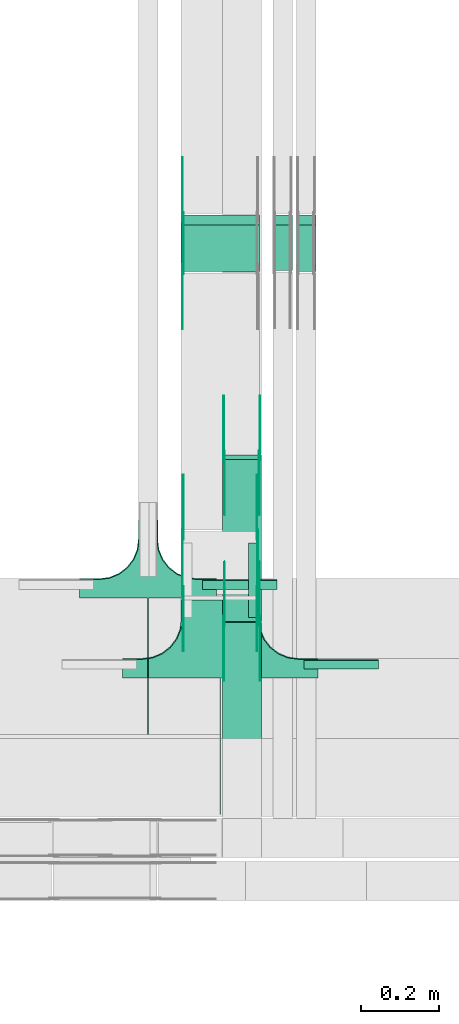
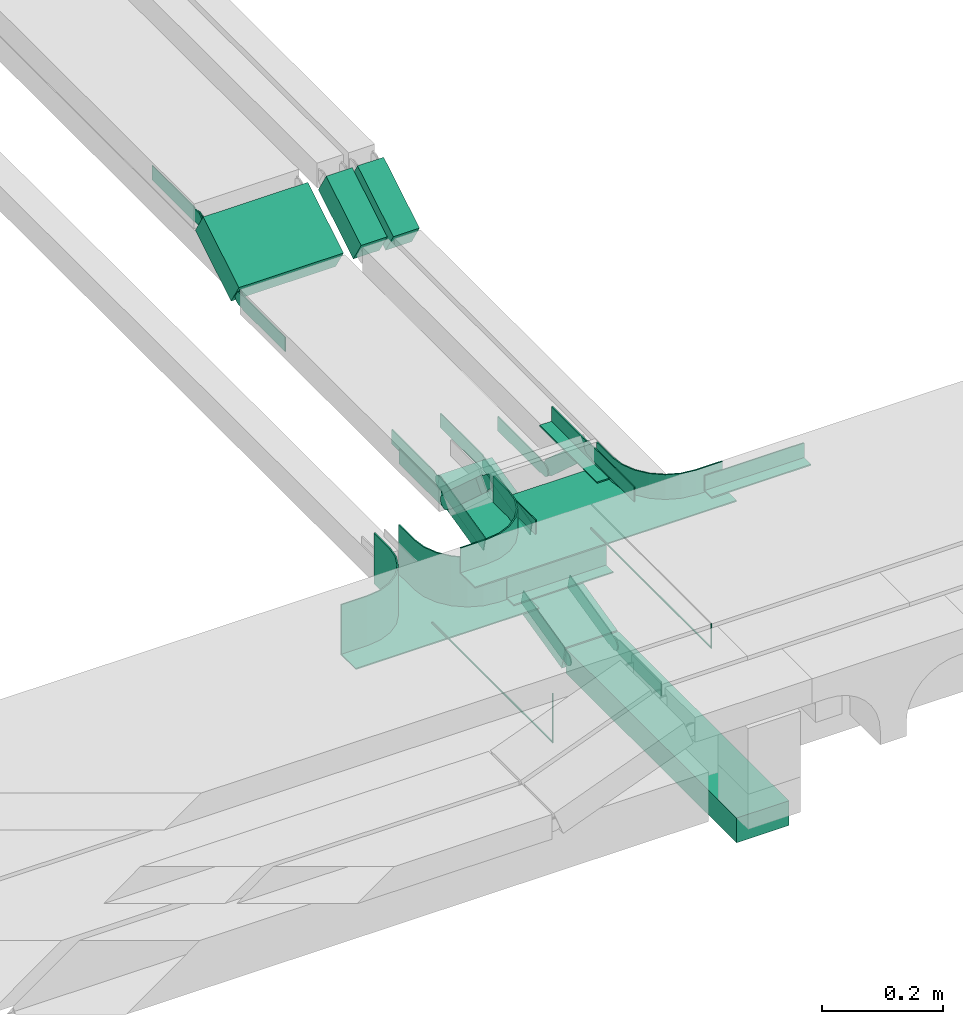
# One storey, part 24 of 27: 25 flow fittings, 5 flow segments.
"""IFC2X3 building model written with IfcOpenShell, lengths in millimetres."""

from ifc_helpers import new_model, entity, si_unit, converted_unit, derived_unit, direction, frame, frame_2d, origin, origin_2d_with_axis, place, context, subcontext, project, spatial, polyline, circle_curve, parameter, trimmed, segment, composite_curve, rectangle, outline, extrude, faceted_brep, source, transform, mapped, material, type_object, type_shapes, element, save


model = new_model("IFC2X3")

# Units and contexts
model_context = context("Model", 3, precision=0.01, world=origin(), true_north=direction((6.12303176911189e-17, 1.0)))
body_context = subcontext(model_context, "Body", "Model", "MODEL_VIEW")
ifc_project = project(units=[si_unit("LENGTHUNIT", "METRE", prefix="MILLI"), si_unit("AREAUNIT", "SQUARE_METRE"), si_unit("VOLUMEUNIT", "CUBIC_METRE"), converted_unit("PLANEANGLEUNIT", "DEGREE", entity("IfcRatioMeasure", 0.0174532925199433), si_unit("PLANEANGLEUNIT", "RADIAN"), dimensions=[0, 0, 0, 0, 0, 0, 0]), si_unit("MASSUNIT", "GRAM", prefix="KILO"), derived_unit("MASSDENSITYUNIT", [(si_unit("MASSUNIT", "GRAM", prefix="KILO"), 1), (si_unit("LENGTHUNIT", "METRE"), -3)]), derived_unit("MOMENTOFINERTIAUNIT", [(si_unit("LENGTHUNIT", "METRE"), 4)]), si_unit("TIMEUNIT", "SECOND"), si_unit("FREQUENCYUNIT", "HERTZ"), si_unit("THERMODYNAMICTEMPERATUREUNIT", "DEGREE_CELSIUS"), derived_unit("THERMALTRANSMITTANCEUNIT", [(si_unit("MASSUNIT", "GRAM", prefix="KILO"), 1), (si_unit("THERMODYNAMICTEMPERATUREUNIT", "KELVIN"), -1), (si_unit("TIMEUNIT", "SECOND"), -3)]), derived_unit("VOLUMETRICFLOWRATEUNIT", [(si_unit("LENGTHUNIT", "METRE"), 3), (si_unit("TIMEUNIT", "SECOND"), -1)]), derived_unit("MASSFLOWRATEUNIT", [(si_unit("MASSUNIT", "GRAM", prefix="KILO"), 1), (si_unit("TIMEUNIT", "SECOND"), -1)]), derived_unit("ROTATIONALFREQUENCYUNIT", [(si_unit("TIMEUNIT", "SECOND"), -1)]), si_unit("ELECTRICCURRENTUNIT", "AMPERE"), si_unit("ELECTRICVOLTAGEUNIT", "VOLT"), si_unit("POWERUNIT", "WATT"), si_unit("FORCEUNIT", "NEWTON", prefix="KILO"), si_unit("ILLUMINANCEUNIT", "LUX"), si_unit("LUMINOUSFLUXUNIT", "LUMEN"), si_unit("LUMINOUSINTENSITYUNIT", "CANDELA"), derived_unit("USERDEFINED", [(si_unit("MASSUNIT", "GRAM", prefix="KILO"), -1), (si_unit("LENGTHUNIT", "METRE"), -2), (si_unit("TIMEUNIT", "SECOND"), 3), (si_unit("LUMINOUSFLUXUNIT", "LUMEN"), 1)]), derived_unit("LINEARVELOCITYUNIT", [(si_unit("LENGTHUNIT", "METRE"), 1), (si_unit("TIMEUNIT", "SECOND"), -1)]), si_unit("PRESSUREUNIT", "PASCAL"), derived_unit("USERDEFINED", [(si_unit("LENGTHUNIT", "METRE"), -2), (si_unit("MASSUNIT", "GRAM", prefix="KILO"), 1), (si_unit("TIMEUNIT", "SECOND"), -2)]), derived_unit("LINEARFORCEUNIT", [(si_unit("MASSUNIT", "GRAM", prefix="KILO"), 1), (si_unit("LENGTHUNIT", "METRE"), 1), (si_unit("TIMEUNIT", "SECOND"), -2), (si_unit("LENGTHUNIT", "METRE"), -1)]), derived_unit("PLANARFORCEUNIT", [(si_unit("MASSUNIT", "GRAM", prefix="KILO"), 1), (si_unit("LENGTHUNIT", "METRE"), 1), (si_unit("TIMEUNIT", "SECOND"), -2), (si_unit("LENGTHUNIT", "METRE"), -2)])], contexts=[model_context])

# Site, building, storey
site_placement = place(None, origin())
site = spatial("IfcSite", under=ifc_project, at=site_placement, CompositionType="ELEMENT")
building_placement = place(site_placement, origin())
building = spatial("IfcBuilding", under=site, at=building_placement, CompositionType="ELEMENT")
storey_placement = place(building_placement, origin())
storey = spatial("IfcBuildingStorey", under=building, at=storey_placement, CompositionType="ELEMENT", Elevation=0.0)

# Flow segments
cable_carrier_segment_type = type_object("IfcCableCarrierSegmentType", PredefinedType="CABLETRAYSEGMENT")
flow_segment_1_placement = place(storey_placement, frame((64007.77, 8447.3, 2500.0)))
element("IfcFlowSegment", 1, at=flow_segment_1_placement, inside=storey, type_object=cable_carrier_segment_type, context=body_context, shape_type="SweptSolid", body=[
    extrude(rectangle(XDim=564.4481580588, YDim=99.9999999999946, at=origin_2d_with_axis()), frame((50.0, 282.22, 0.0), z_axis=(0.0, 0.0, 1.0), x_axis=(0.0, -1.0, 0.0)), (0.0, 0.0, 1.0), 49.9999999999995),
])
flow_segment_2_placement = place(storey_placement, frame((64007.77, 9014.64, 2501.67)))
element("IfcFlowSegment", 2, at=flow_segment_2_placement, inside=storey, type_object=cable_carrier_segment_type, context=body_context, shape_type="SweptSolid", body=[
    extrude(rectangle(XDim=49.9999999999991, YDim=426.657179477844, at=frame_2d((0.0, 0.0), x_axis=(0.0, 1.0))), frame((0.0, 213.37, 73.33), z_axis=(1.0, 0.0, 0.0), x_axis=(0.0, -0.973268623518936, -0.229669733472993)), (0.0, 0.0, 1.0), 99.9999999999945),
])
flow_segment_3_placement = place(storey_placement, frame((63902.18, 9911.58, 2727.77)))
element("IfcFlowSegment", 3, at=flow_segment_3_placement, inside=storey, type_object=cable_carrier_segment_type, context=body_context, shape_type="SweptSolid", body=[
    extrude(rectangle(XDim=49.9999999999983, YDim=138.128101267282, at=frame_2d((0.0, 0.0), x_axis=(0.0, 1.0))), frame((0.0, 72.08, 57.0), z_axis=(1.0, 0.0, 0.0), x_axis=(0.0, -0.857167300695768, -0.515038074920613)), (0.0, 0.0, 1.0), 200.000000000007),
])
flow_segment_4_placement = place(storey_placement, frame((64137.18, 9914.0, 2729.23)))
element("IfcFlowSegment", 4, at=flow_segment_4_placement, inside=storey, type_object=cable_carrier_segment_type, context=body_context, shape_type="SweptSolid", body=[
    extrude(rectangle(XDim=49.9999999999983, YDim=135.30189452444, at=frame_2d((0.0, 0.0), x_axis=(0.0, 1.0))), frame((0.0, 70.86, 56.27), z_axis=(1.0, 0.0, 0.0), x_axis=(0.0, 0.857167300702146, 0.515038074909999)), (0.0, 0.0, 1.0), 50.0000000000059),
])
flow_segment_5_placement = place(storey_placement, frame((64197.18, 9911.15, 2727.52)))
element("IfcFlowSegment", 5, at=flow_segment_5_placement, inside=storey, type_object=cable_carrier_segment_type, context=body_context, shape_type="SweptSolid", body=[
    extrude(rectangle(XDim=49.9999999999981, YDim=138.627629637819, at=frame_2d((0.0, 0.0), x_axis=(0.0, 1.0))), frame((0.0, 72.29, 57.13), z_axis=(1.0, 0.0, 0.0), x_axis=(0.0, 0.857167300695404, 0.515038074921219)), (0.0, 0.0, 1.0), 50.000000000006),
])

# Flow fittings
ifc_material_1 = material()
cable_carrier_fitting_type_1 = type_object("IfcCableCarrierFittingType", PredefinedType="NOTDEFINED", material=ifc_material_1)
shared_shape_1 = source(origin(), body_context, "Body", "SweptSolid", [
    extrude(outline(polyline([(-9.17, -21.5), (15.83, -21.5), (15.83, -19.0), (-6.67, -19.0), (-6.67, 40.5), (-9.17, 40.5), (-9.17, -21.5)])), frame((-95.0, 9.17, -26.0), z_axis=(1.0, 0.0, 0.0), x_axis=(0.0, 1.0, 0.0)), (0.0, 0.0, 1.0), 190.0),
])
type_shapes(cable_carrier_fitting_type_1, [shared_shape_1])
flow_fitting_1_placement = place(storey_placement, frame((64052.18, 9121.83, 2650.0), z_axis=(0.0, 0.0, 1.0), x_axis=(-1.0, 0.0, 0.0)))
element("IfcFlowFitting", 6, at=flow_fitting_1_placement, inside=storey, type_object=cable_carrier_fitting_type_1, material=ifc_material_1, context=body_context, shape_type="MappedRepresentation", body=[
    mapped(shared_shape_1, transform((0.0, 0.0, 0.0), scale=1.0)),
])
cable_carrier_fitting_type_2 = type_object("IfcCableCarrierFittingType", PredefinedType="NOTDEFINED", material=ifc_material_1)
shared_shape_2 = source(origin(), body_context, "Body", "SweptSolid", [
    extrude(outline(polyline([(-9.17, -11.5), (15.83, -11.5), (15.83, -9.0), (-6.67, -9.0), (-6.67, 20.5), (-9.17, 20.5), (-9.17, -11.5)])), frame((-95.0, 9.17, -11.0), z_axis=(1.0, 0.0, 0.0), x_axis=(0.0, 1.0, 0.0)), (0.0, 0.0, 1.0), 190.0),
])
type_shapes(cable_carrier_fitting_type_2, [shared_shape_2])
for number, where, z_axis, x_axis in (
    (7, (64312.18, 8917.5, 2875.0), (0.0, 0.0, 1.0), (-1.0, 0.0, 0.0)),
    (8, (64099.68, 9120.0, 2875.0), (0.0, 0.0, 1.0), (0.0, 1.0, 0.0)),
):
    element("IfcFlowFitting", number, at=place(storey_placement, frame(where, z_axis=z_axis, x_axis=x_axis)), inside=storey, type_object=cable_carrier_fitting_type_2, material=ifc_material_1, context=body_context, shape_type="MappedRepresentation", body=[
        mapped(shared_shape_2, transform((0.0, 0.0, 0.0), scale=1.0)),
    ])
cable_carrier_fitting_type_3 = type_object("IfcCableCarrierFittingType", PredefinedType="NOTDEFINED", material=ifc_material_1)
shared_shape_3 = source(origin(), body_context, "Body", "Brep", [
    faceted_brep([(1.0, 197.5, 50.0), (1.0, 197.5, -47.5), (1.0, -200.0, -47.5), (1.0, -200.0, -50.0), (1.0, 200.0, -50.0), (1.0, 200.0, 50.0), (-1.0, 197.5, 50.0), (-1.0, 200.0, 50.0), (-1.0, 200.0, -50.0), (-1.0, -200.0, -50.0), (-1.0, -200.0, -47.5), (-1.0, 197.5, -47.5)], [[[0, 1, 2, 3, 4, 5]], [[6, 7, 8, 9, 10, 11]], [[1, 0, 6, 11]], [[2, 1, 11, 10]], [[3, 2, 10, 9]], [[4, 3, 9, 8]], [[5, 4, 8, 7]], [[0, 5, 7, 6]]]),
    faceted_brep([(22.5, -300.0, 50.0), (22.5, -350.0, 50.0), (25.0, -350.0, 50.0), (25.0, -300.0, 50.0), (28.41, -274.12, 50.0), (38.4, -250.0, 50.0), (54.29, -229.29, 50.0), (75.0, -213.4, 50.0), (99.12, -203.41, 50.0), (125.0, -200.0, 50.0), (175.0, -200.0, 50.0), (175.0, -197.5, 50.0), (125.0, -197.5, 50.0), (98.47, -200.99, 50.0), (73.75, -211.23, 50.0), (52.52, -227.52, 50.0), (36.23, -248.75, 50.0), (25.99, -273.47, 50.0), (-99.12, -203.41, 50.0), (-75.0, -213.4, 50.0), (-54.29, -229.29, 50.0), (-38.4, -250.0, 50.0), (-28.41, -274.12, 50.0), (-25.0, -300.0, 50.0), (-25.0, -350.0, 50.0), (-22.5, -350.0, 50.0), (-22.5, -300.0, 50.0), (-25.99, -273.47, 50.0), (-36.23, -248.75, 50.0), (-52.52, -227.52, 50.0), (-73.75, -211.23, 50.0), (-98.47, -200.99, 50.0), (-125.0, -197.5, 50.0), (-175.0, -197.5, 50.0), (-175.0, -200.0, 50.0), (-125.0, -200.0, 50.0), (-99.12, -203.41, -50.0), (-114.21, -201.42, -50.0), (-125.0, -200.0, -50.0), (-125.0, -200.0, -52.5), (-112.06, -201.7, -52.5), (-99.12, -203.41, -52.5), (-75.0, -213.4, -50.0), (-87.06, -208.4, -50.0), (-87.06, -208.4, -52.5), (-75.0, -213.4, -52.5), (-64.64, -221.34, -50.0), (-54.29, -229.29, -50.0), (-64.64, -221.34, -52.5), (-54.29, -229.29, -52.5), (-28.41, -274.12, -50.0), (-33.4, -262.06, -50.0), (-38.4, -250.0, -50.0), (-38.4, -250.0, -52.5), (-33.4, -262.06, -52.5), (-28.41, -274.12, -52.5), (-25.0, -300.0, -50.0), (-26.7, -287.06, -50.0), (-26.42, -289.21, -52.5), (-25.0, -300.0, -52.5), (-46.34, -239.64, -50.0), (-46.34, -239.64, -52.5), (-25.0, -350.0, -52.5), (25.0, -350.0, -52.5), (22.5, -350.0, -50.0), (-22.5, -350.0, -50.0), (-22.5, -300.0, -50.0), (-25.99, -273.47, -50.0), (-36.23, -248.75, -50.0), (-52.52, -227.52, -50.0), (-73.75, -211.23, -50.0), (-98.47, -200.99, -50.0), (-125.0, -197.5, -50.0), (25.0, -300.0, -52.5), (25.0, -300.0, -50.0), (28.41, -274.12, -50.0), (33.4, -262.06, -50.0), (38.4, -250.0, -50.0), (28.41, -274.12, -52.5), (33.4, -262.06, -52.5), (38.4, -250.0, -52.5), (46.34, -239.64, -50.0), (54.29, -229.29, -50.0), (46.34, -239.64, -52.5), (54.29, -229.29, -52.5), (26.42, -289.21, -50.0), (26.7, -287.06, -52.5), (75.0, -213.4, -50.0), (87.06, -208.4, -50.0), (99.12, -203.41, -50.0), (75.0, -213.4, -52.5), (87.06, -208.4, -52.5), (99.12, -203.41, -52.5), (112.06, -201.7, -50.0), (125.0, -200.0, -50.0), (114.21, -201.42, -52.5), (125.0, -200.0, -52.5), (64.64, -221.34, -50.0), (64.64, -221.34, -52.5), (98.47, -200.99, -50.0), (73.75, -211.23, -50.0), (52.52, -227.52, -50.0), (125.0, -197.5, -50.0), (36.23, -248.75, -50.0), (25.99, -273.47, -50.0), (22.5, -300.0, -50.0), (-175.0, -197.5, -50.0), (175.0, -197.5, -50.0), (-175.0, -150.0, -50.0), (-175.0, -150.0, -52.5), (-175.0, -200.0, -52.5), (175.0, -200.0, -52.5), (175.0, -150.0, -52.5), (175.0, -150.0, -50.0)], [[[0, 1, 2, 3, 4, 5, 6, 7, 8, 9, 10, 11, 12, 13, 14, 15, 16, 17]], [[18, 19, 20, 21, 22, 23, 24, 25, 26, 27, 28, 29, 30, 31, 32, 33, 34, 35]], [[18, 35, 36]], [[35, 37, 36]], [[35, 38, 37]], [[37, 38, 39]], [[37, 39, 40]], [[36, 40, 41]], [[37, 40, 36]], [[19, 18, 42]], [[18, 43, 42]], [[18, 36, 43]], [[36, 41, 43]], [[44, 43, 41]], [[43, 44, 42]], [[44, 45, 42]], [[19, 42, 46]], [[19, 46, 47]], [[47, 20, 19]], [[46, 42, 45]], [[46, 45, 48]], [[48, 49, 47]], [[46, 48, 47]], [[22, 21, 50]], [[21, 51, 50]], [[21, 52, 51]], [[52, 53, 51]], [[54, 51, 53]], [[51, 54, 50]], [[54, 55, 50]], [[23, 22, 56]], [[22, 57, 56]], [[22, 50, 57]], [[50, 55, 57]], [[58, 57, 55]], [[58, 59, 56]], [[57, 58, 56]], [[20, 47, 60]], [[20, 60, 52]], [[52, 21, 20]], [[60, 47, 49]], [[60, 49, 61]], [[60, 61, 52]], [[61, 53, 52]], [[24, 23, 56, 59, 62]], [[25, 24, 62, 63, 2, 1, 64, 65]], [[26, 25, 65, 66]], [[27, 67, 68, 28]], [[28, 68, 69, 29]], [[66, 67, 27, 26]], [[30, 70, 71, 31]], [[31, 71, 72, 32]], [[29, 69, 70, 30]], [[3, 2, 63, 73, 74]], [[5, 4, 75]], [[5, 75, 76]], [[5, 76, 77]], [[75, 78, 76]], [[79, 76, 78]], [[76, 79, 77]], [[79, 80, 77]], [[6, 5, 77]], [[6, 77, 81]], [[6, 81, 82]], [[81, 77, 80]], [[81, 80, 83]], [[83, 84, 82]], [[81, 83, 82]], [[74, 4, 3]], [[4, 74, 85]], [[85, 74, 73]], [[85, 73, 86]], [[85, 86, 75]], [[75, 86, 78]], [[4, 85, 75]], [[8, 7, 87]], [[8, 87, 88]], [[8, 88, 89]], [[87, 90, 88]], [[91, 88, 90]], [[88, 91, 89]], [[91, 92, 89]], [[9, 8, 89]], [[9, 89, 93]], [[9, 93, 94]], [[89, 92, 93]], [[95, 93, 92]], [[95, 96, 94]], [[93, 95, 94]], [[7, 82, 97]], [[6, 82, 7]], [[7, 97, 87]], [[97, 82, 84]], [[97, 84, 98]], [[97, 98, 87]], [[98, 90, 87]], [[13, 99, 100, 14]], [[14, 100, 101, 15]], [[102, 99, 13, 12]], [[16, 103, 104, 17]], [[17, 104, 105, 0]], [[15, 101, 103, 16]], [[1, 0, 105, 64]], [[33, 32, 72, 106]], [[12, 11, 107, 102]], [[34, 33, 106, 108, 109, 110]], [[35, 34, 110, 39, 38]], [[10, 9, 94, 96, 111]], [[10, 111, 112, 113, 107, 11]], [[107, 113, 108, 106, 72, 71, 70, 69, 68, 67, 66, 65, 64, 105, 104, 103, 101, 100, 99, 102]], [[110, 109, 112, 111, 96, 95, 92, 91, 90, 98, 84, 83, 80, 79, 78, 86, 73, 63, 62, 59, 58, 55, 54, 53, 61, 49, 48, 45, 44, 41, 40, 39]], [[108, 113, 112, 109]]]),
])
type_shapes(cable_carrier_fitting_type_3, [shared_shape_3])
flow_fitting_2_placement = place(storey_placement, frame((63817.18, 8924.33, 2650.0), z_axis=(0.0, 0.0, 1.0), x_axis=(-1.0, 0.0, 0.0)))
element("IfcFlowFitting", 9, at=flow_fitting_2_placement, inside=storey, type_object=cable_carrier_fitting_type_3, material=ifc_material_1, context=body_context, shape_type="MappedRepresentation", body=[
    mapped(shared_shape_3, transform((0.0, 0.0, 0.0), scale=1.0)),
])
cable_carrier_fitting_type_4 = type_object("IfcCableCarrierFittingType", PredefinedType="NOTDEFINED", material=ifc_material_1)
shared_shape_4 = source(origin(), body_context, "Body", "Brep", [
    faceted_brep([(1.0, 197.5, 25.0), (1.0, 197.5, -22.5), (1.0, -200.0, -22.5), (1.0, -200.0, -25.0), (1.0, 200.0, -25.0), (1.0, 200.0, 25.0), (-1.0, 197.5, 25.0), (-1.0, 200.0, 25.0), (-1.0, 200.0, -25.0), (-1.0, -200.0, -25.0), (-1.0, -200.0, -22.5), (-1.0, 197.5, -22.5)], [[[0, 1, 2, 3, 4, 5]], [[6, 7, 8, 9, 10, 11]], [[1, 0, 6, 11]], [[2, 1, 11, 10]], [[3, 2, 10, 9]], [[4, 3, 9, 8]], [[5, 4, 8, 7]], [[0, 5, 7, 6]]]),
    faceted_brep([(97.5, -300.0, 25.0), (97.5, -350.0, 25.0), (100.0, -350.0, 25.0), (100.0, -300.0, 25.0), (103.41, -274.12, 25.0), (113.4, -250.0, 25.0), (129.29, -229.29, 25.0), (150.0, -213.4, 25.0), (174.12, -203.41, 25.0), (200.0, -200.0, 25.0), (250.0, -200.0, 25.0), (250.0, -197.5, 25.0), (200.0, -197.5, 25.0), (173.47, -200.99, 25.0), (148.75, -211.23, 25.0), (127.52, -227.52, 25.0), (111.23, -248.75, 25.0), (100.99, -273.47, 25.0), (-174.12, -203.41, 25.0), (-150.0, -213.4, 25.0), (-129.29, -229.29, 25.0), (-113.4, -250.0, 25.0), (-103.41, -274.12, 25.0), (-100.0, -300.0, 25.0), (-100.0, -350.0, 25.0), (-97.5, -350.0, 25.0), (-97.5, -300.0, 25.0), (-100.99, -273.47, 25.0), (-111.23, -248.75, 25.0), (-127.52, -227.52, 25.0), (-148.75, -211.23, 25.0), (-173.47, -200.99, 25.0), (-200.0, -197.5, 25.0), (-250.0, -197.5, 25.0), (-250.0, -200.0, 25.0), (-200.0, -200.0, 25.0), (-200.0, -200.0, -25.0), (-189.21, -201.42, -25.0), (-174.12, -203.41, -25.0), (-200.0, -200.0, -27.5), (-187.06, -201.7, -27.5), (-174.12, -203.41, -27.5), (-162.06, -208.4, -25.0), (-150.0, -213.4, -25.0), (-162.06, -208.4, -27.5), (-150.0, -213.4, -27.5), (-139.64, -221.34, -25.0), (-129.29, -229.29, -25.0), (-139.64, -221.34, -27.5), (-129.29, -229.29, -27.5), (-113.4, -250.0, -25.0), (-108.4, -262.06, -25.0), (-103.41, -274.12, -25.0), (-113.4, -250.0, -27.5), (-108.4, -262.06, -27.5), (-103.41, -274.12, -27.5), (-101.7, -287.06, -25.0), (-100.0, -300.0, -25.0), (-101.42, -289.21, -27.5), (-100.0, -300.0, -27.5), (-121.34, -239.64, -25.0), (-121.34, -239.64, -27.5), (-100.0, -350.0, -27.5), (100.0, -350.0, -27.5), (97.5, -350.0, -25.0), (-97.5, -350.0, -25.0), (-97.5, -300.0, -25.0), (-100.99, -273.47, -25.0), (-111.23, -248.75, -25.0), (-127.52, -227.52, -25.0), (-148.75, -211.23, -25.0), (-173.47, -200.99, -25.0), (-200.0, -197.5, -25.0), (100.0, -300.0, -27.5), (100.0, -300.0, -25.0), (103.41, -274.12, -25.0), (101.42, -289.21, -25.0), (101.7, -287.06, -27.5), (103.41, -274.12, -27.5), (113.4, -250.0, -25.0), (108.4, -262.06, -25.0), (108.4, -262.06, -27.5), (113.4, -250.0, -27.5), (121.34, -239.64, -25.0), (129.29, -229.29, -25.0), (121.34, -239.64, -27.5), (129.29, -229.29, -27.5), (150.0, -213.4, -25.0), (139.64, -221.34, -25.0), (139.64, -221.34, -27.5), (150.0, -213.4, -27.5), (174.12, -203.41, -25.0), (162.06, -208.4, -25.0), (162.06, -208.4, -27.5), (174.12, -203.41, -27.5), (187.06, -201.7, -25.0), (200.0, -200.0, -25.0), (189.21, -201.42, -27.5), (200.0, -200.0, -27.5), (200.0, -197.5, -25.0), (173.47, -200.99, -25.0), (148.75, -211.23, -25.0), (127.52, -227.52, -25.0), (111.23, -248.75, -25.0), (100.99, -273.47, -25.0), (97.5, -300.0, -25.0), (-250.0, -197.5, -25.0), (250.0, -197.5, -25.0), (-250.0, -150.0, -25.0), (-250.0, -150.0, -27.5), (-250.0, -200.0, -27.5), (250.0, -200.0, -27.5), (250.0, -150.0, -27.5), (250.0, -150.0, -25.0)], [[[0, 1, 2, 3, 4, 5, 6, 7, 8, 9, 10, 11, 12, 13, 14, 15, 16, 17]], [[18, 19, 20, 21, 22, 23, 24, 25, 26, 27, 28, 29, 30, 31, 32, 33, 34, 35]], [[18, 35, 36]], [[18, 36, 37]], [[18, 37, 38]], [[37, 36, 39]], [[37, 39, 40]], [[38, 40, 41]], [[37, 40, 38]], [[19, 18, 38]], [[19, 38, 42]], [[19, 42, 43]], [[38, 41, 42]], [[44, 42, 41]], [[42, 44, 43]], [[44, 45, 43]], [[20, 43, 46]], [[19, 43, 20]], [[20, 46, 47]], [[46, 43, 45]], [[46, 45, 48]], [[48, 49, 47]], [[46, 48, 47]], [[22, 21, 50]], [[22, 50, 51]], [[22, 51, 52]], [[50, 53, 51]], [[54, 51, 53]], [[51, 54, 52]], [[54, 55, 52]], [[23, 22, 52]], [[23, 52, 56]], [[23, 56, 57]], [[52, 55, 56]], [[58, 56, 55]], [[58, 59, 57]], [[56, 58, 57]], [[21, 47, 60]], [[20, 47, 21]], [[21, 60, 50]], [[60, 47, 49]], [[60, 49, 61]], [[60, 61, 50]], [[61, 53, 50]], [[24, 23, 57, 59, 62]], [[25, 24, 62, 63, 2, 1, 64, 65]], [[26, 25, 65, 66]], [[27, 26, 66, 67]], [[28, 27, 67, 68]], [[29, 28, 68, 69]], [[30, 29, 69, 70]], [[31, 30, 70, 71]], [[32, 31, 71, 72]], [[3, 2, 63, 73, 74]], [[4, 3, 75]], [[3, 76, 75]], [[3, 74, 76]], [[76, 74, 73]], [[76, 73, 77]], [[75, 77, 78]], [[76, 77, 75]], [[5, 4, 79]], [[4, 80, 79]], [[4, 75, 80]], [[75, 78, 80]], [[81, 80, 78]], [[80, 81, 79]], [[81, 82, 79]], [[5, 79, 83]], [[5, 83, 84]], [[84, 6, 5]], [[83, 79, 82]], [[83, 82, 85]], [[85, 86, 84]], [[83, 85, 84]], [[7, 6, 87]], [[6, 88, 87]], [[6, 84, 88]], [[88, 84, 86]], [[88, 86, 89]], [[88, 89, 87]], [[89, 90, 87]], [[8, 7, 91]], [[7, 92, 91]], [[7, 87, 92]], [[87, 90, 92]], [[93, 92, 90]], [[92, 93, 91]], [[93, 94, 91]], [[8, 91, 95]], [[8, 95, 96]], [[8, 96, 9]], [[91, 94, 95]], [[97, 95, 94]], [[97, 98, 96]], [[95, 97, 96]], [[13, 12, 99, 100]], [[14, 13, 100, 101]], [[15, 14, 101, 102]], [[102, 103, 16, 15]], [[17, 16, 103, 104]], [[104, 105, 0, 17]], [[1, 0, 105, 64]], [[33, 32, 72, 106]], [[12, 11, 107, 99]], [[34, 33, 106, 108, 109, 110]], [[35, 34, 110, 39, 36]], [[10, 9, 96, 98, 111]], [[10, 111, 112, 113, 107, 11]], [[107, 113, 108, 106, 72, 71, 70, 69, 68, 67, 66, 65, 64, 105, 104, 103, 102, 101, 100, 99]], [[110, 109, 112, 111, 98, 97, 94, 93, 90, 89, 86, 85, 82, 81, 78, 77, 73, 63, 62, 59, 58, 55, 54, 53, 61, 49, 48, 45, 44, 41, 40, 39]], [[108, 113, 112, 109]]]),
])
type_shapes(cable_carrier_fitting_type_4, [shared_shape_4])
flow_fitting_3_placement = place(storey_placement, frame((64002.18, 8720.0, 2875.0), z_axis=(0.0, 0.0, 1.0), x_axis=(-1.0, 0.0, 0.0)))
element("IfcFlowFitting", 10, at=flow_fitting_3_placement, inside=storey, type_object=cable_carrier_fitting_type_4, material=ifc_material_1, context=body_context, shape_type="MappedRepresentation", body=[
    mapped(shared_shape_4, transform((0.0, 0.0, 0.0), scale=1.0)),
])
ifc_material_2 = material(Name="G")
cable_carrier_fitting_type_5 = type_object("IfcCableCarrierFittingType", PredefinedType="NOTDEFINED", material=ifc_material_2)
shared_shape_5 = source(origin(), body_context, "Body", "SweptSolid", [
    extrude(outline(composite_curve([segment(trimmed(circle_curve(frame_2d((-44.59, 0.0), x_axis=(1.0, 0.0)), 12.5), [parameter(90.0000000000007)], [parameter(270.0)], True, "PARAMETER"), True, "CONTINUOUS"), segment(polyline([(-44.59, -12.5), (-33.09, -12.5)]), True, "CONTINUOUS"), segment(polyline([(-33.09, -12.5), (-31.23, -14.5)]), True, "CONTINUOUS"), segment(polyline([(-31.23, -14.5), (108.91, -14.5)]), True, "CONTINUOUS"), segment(polyline([(108.91, -14.5), (108.91, 14.5)]), True, "CONTINUOUS"), segment(polyline([(108.91, 14.5), (-31.23, 14.5)]), True, "CONTINUOUS"), segment(polyline([(-31.23, 14.5), (-33.09, 12.5)]), True, "CONTINUOUS"), segment(polyline([(-33.09, 12.5), (-44.59, 12.5)]), True, "CONTINUOUS")], self_intersect=False)), frame((44.59, 0.0, 0.0), z_axis=(0.0, 0.0, -1.0), x_axis=(1.0, 0.0, 0.0)), (0.0, 0.0, -1.0), 2.0),
])
type_shapes(cable_carrier_fitting_type_5, [shared_shape_5])
flow_fitting_4_placement = place(storey_placement, frame((64012.31, 9439.9, 2625.0), z_axis=(-1.0, 0.0, 0.0), x_axis=(0.0, 1.0, 0.0)))
element("IfcFlowFitting", 11, at=flow_fitting_4_placement, inside=storey, type_object=cable_carrier_fitting_type_5, material=ifc_material_2, context=body_context, shape_type="MappedRepresentation", body=[
    mapped(shared_shape_5, transform((0.0, 0.0, 0.0), scale=1.0)),
])
cable_carrier_fitting_type_6 = type_object("IfcCableCarrierFittingType", PredefinedType="NOTDEFINED", material=ifc_material_2)
type_shapes(cable_carrier_fitting_type_6, [shared_shape_5])
flow_fitting_5_placement = place(storey_placement, frame((64101.23, 9439.9, 2625.0), z_axis=(1.0, 0.0, 0.0), x_axis=(0.0, -0.973268623517802, -0.229669733477801)))
element("IfcFlowFitting", 12, at=flow_fitting_5_placement, inside=storey, type_object=cable_carrier_fitting_type_6, material=ifc_material_2, context=body_context, shape_type="MappedRepresentation", body=[
    mapped(shared_shape_5, transform((0.0, 0.0, 0.0), scale=1.0)),
])
flow_fitting_6_placement = place(storey_placement, frame((64012.31, 9016.13, 2525.0), z_axis=(-1.0, 0.0, 0.0), x_axis=(0.0, -1.0, 0.0)))
element("IfcFlowFitting", 13, at=flow_fitting_6_placement, inside=storey, type_object=cable_carrier_fitting_type_5, material=ifc_material_2, context=body_context, shape_type="MappedRepresentation", body=[
    mapped(shared_shape_5, transform((0.0, 0.0, 0.0), scale=1.0)),
])
flow_fitting_7_placement = place(storey_placement, frame((64101.23, 9016.13, 2525.0), z_axis=(1.0, 0.0, 0.0), x_axis=(0.0, 0.973268623517807, 0.229669733477778)))
element("IfcFlowFitting", 14, at=flow_fitting_7_placement, inside=storey, type_object=cable_carrier_fitting_type_6, material=ifc_material_2, context=body_context, shape_type="MappedRepresentation", body=[
    mapped(shared_shape_5, transform((0.0, 0.0, 0.0), scale=1.0)),
])
for number, where, z_axis, x_axis in (
    (15, (63906.72, 9916.71, 2744.54), (-1.0, 0.0, 0.0), (0.0, -1.0, 0.0)),
    (16, (63906.72, 9091.79, 2875.0), (-1.0, 0.0, 0.0), (0.0, 0.743144825477395, -0.669130606358858)),
):
    element("IfcFlowFitting", number, at=place(storey_placement, frame(where, z_axis=z_axis, x_axis=x_axis)), inside=storey, type_object=cable_carrier_fitting_type_5, material=ifc_material_2, context=body_context, shape_type="MappedRepresentation", body=[
        mapped(shared_shape_5, transform((0.0, 0.0, 0.0), scale=1.0)),
    ])
flow_fitting_8_placement = place(storey_placement, frame((64095.64, 9091.79, 2875.0), z_axis=(1.0, 0.0, 0.0), x_axis=(0.0, -1.0, 0.0)))
element("IfcFlowFitting", 17, at=flow_fitting_8_placement, inside=storey, type_object=cable_carrier_fitting_type_6, material=ifc_material_2, context=body_context, shape_type="MappedRepresentation", body=[
    mapped(shared_shape_5, transform((0.0, 0.0, 0.0), scale=1.0)),
])
flow_fitting_9_placement = place(storey_placement, frame((63906.72, 9236.67, 2744.54), z_axis=(-1.0, 0.0, 0.0), x_axis=(0.0, -0.743144825477395, 0.669130606358858)))
element("IfcFlowFitting", 18, at=flow_fitting_9_placement, inside=storey, type_object=cable_carrier_fitting_type_5, material=ifc_material_2, context=body_context, shape_type="MappedRepresentation", body=[
    mapped(shared_shape_5, transform((0.0, 0.0, 0.0), scale=1.0)),
])
flow_fitting_10_placement = place(storey_placement, frame((64095.64, 9236.67, 2744.54), z_axis=(1.0, 0.0, 0.0), x_axis=(0.0, 1.0, 0.0)))
element("IfcFlowFitting", 19, at=flow_fitting_10_placement, inside=storey, type_object=cable_carrier_fitting_type_6, material=ifc_material_2, context=body_context, shape_type="MappedRepresentation", body=[
    mapped(shared_shape_5, transform((0.0, 0.0, 0.0), scale=1.0)),
])
flow_fitting_11_placement = place(storey_placement, frame((63906.72, 10050.61, 2825.0), z_axis=(-1.0, 0.0, 0.0), x_axis=(0.0, 1.0, 0.0)))
element("IfcFlowFitting", 20, at=flow_fitting_11_placement, inside=storey, type_object=cable_carrier_fitting_type_5, material=ifc_material_2, context=body_context, shape_type="MappedRepresentation", body=[
    mapped(shared_shape_5, transform((0.0, 0.0, 0.0), scale=1.0)),
])
cable_carrier_fitting_type_7 = type_object("IfcCableCarrierFittingType", PredefinedType="NOTDEFINED", material=ifc_material_2)
shared_shape_6 = source(origin(), body_context, "Body", "SweptSolid", [
    extrude(outline(composite_curve([segment(trimmed(circle_curve(frame_2d((-44.59, 0.0), x_axis=(1.0, 0.0)), 12.5), [parameter(90.0000000000007)], [parameter(270.0)], True, "PARAMETER"), True, "CONTINUOUS"), segment(polyline([(-44.59, -12.5), (-33.09, -12.5)]), True, "CONTINUOUS"), segment(polyline([(-33.09, -12.5), (-31.23, -14.5)]), True, "CONTINUOUS"), segment(polyline([(-31.23, -14.5), (108.91, -14.5)]), True, "CONTINUOUS"), segment(polyline([(108.91, -14.5), (108.91, 14.5)]), True, "CONTINUOUS"), segment(polyline([(108.91, 14.5), (-31.23, 14.5)]), True, "CONTINUOUS"), segment(polyline([(-31.23, 14.5), (-33.09, 12.5)]), True, "CONTINUOUS"), segment(polyline([(-33.09, 12.5), (-44.59, 12.5)]), True, "CONTINUOUS")], self_intersect=False)), frame((44.59, 0.0, 0.0)), (0.0, 0.0, 1.0), 2.0),
])
type_shapes(cable_carrier_fitting_type_7, [shared_shape_6])
flow_fitting_12_placement = place(storey_placement, frame((64103.23, 9439.9, 2625.0), z_axis=(1.0, 0.0, 0.0), x_axis=(0.0, 1.0, 0.0)))
element("IfcFlowFitting", 21, at=flow_fitting_12_placement, inside=storey, type_object=cable_carrier_fitting_type_7, material=ifc_material_2, context=body_context, shape_type="MappedRepresentation", body=[
    mapped(shared_shape_6, transform((0.0, 0.0, 0.0), scale=1.0)),
])
cable_carrier_fitting_type_8 = type_object("IfcCableCarrierFittingType", PredefinedType="NOTDEFINED", material=ifc_material_2)
type_shapes(cable_carrier_fitting_type_8, [shared_shape_6])
flow_fitting_13_placement = place(storey_placement, frame((64014.31, 9439.9, 2625.0), z_axis=(-1.0, 0.0, 0.0), x_axis=(0.0, -0.973268623517802, -0.229669733477801)))
element("IfcFlowFitting", 22, at=flow_fitting_13_placement, inside=storey, type_object=cable_carrier_fitting_type_8, material=ifc_material_2, context=body_context, shape_type="MappedRepresentation", body=[
    mapped(shared_shape_6, transform((0.0, 0.0, 0.0), scale=1.0)),
])
flow_fitting_14_placement = place(storey_placement, frame((64103.23, 9016.13, 2525.0), z_axis=(1.0, 0.0, 0.0), x_axis=(0.0, -1.0, 0.0)))
element("IfcFlowFitting", 23, at=flow_fitting_14_placement, inside=storey, type_object=cable_carrier_fitting_type_7, material=ifc_material_2, context=body_context, shape_type="MappedRepresentation", body=[
    mapped(shared_shape_6, transform((0.0, 0.0, 0.0), scale=1.0)),
])
for number, where, z_axis, x_axis in (
    (24, (64014.31, 9016.13, 2525.0), (-1.0, 0.0, 0.0), (0.0, 0.973268623517807, 0.229669733477778)),
    (25, (63908.72, 9916.71, 2744.54), (-1.0, 0.0, 0.0), (0.0, 0.857167300697282, 0.515038074918093)),
):
    element("IfcFlowFitting", number, at=place(storey_placement, frame(where, z_axis=z_axis, x_axis=x_axis)), inside=storey, type_object=cable_carrier_fitting_type_8, material=ifc_material_2, context=body_context, shape_type="MappedRepresentation", body=[
        mapped(shared_shape_6, transform((0.0, 0.0, 0.0), scale=1.0)),
    ])
flow_fitting_15_placement = place(storey_placement, frame((64097.64, 9091.79, 2875.0), z_axis=(1.0, 0.0, 0.0), x_axis=(0.0, 0.743144825477395, -0.669130606358858)))
element("IfcFlowFitting", 26, at=flow_fitting_15_placement, inside=storey, type_object=cable_carrier_fitting_type_7, material=ifc_material_2, context=body_context, shape_type="MappedRepresentation", body=[
    mapped(shared_shape_6, transform((0.0, 0.0, 0.0), scale=1.0)),
])
flow_fitting_16_placement = place(storey_placement, frame((63908.72, 9091.79, 2875.0), z_axis=(-1.0, 0.0, 0.0), x_axis=(0.0, -1.0, 0.0)))
element("IfcFlowFitting", 27, at=flow_fitting_16_placement, inside=storey, type_object=cable_carrier_fitting_type_8, material=ifc_material_2, context=body_context, shape_type="MappedRepresentation", body=[
    mapped(shared_shape_6, transform((0.0, 0.0, 0.0), scale=1.0)),
])
flow_fitting_17_placement = place(storey_placement, frame((64097.64, 9236.67, 2744.54), z_axis=(1.0, 0.0, 0.0), x_axis=(0.0, -0.743144825477395, 0.669130606358858)))
element("IfcFlowFitting", 28, at=flow_fitting_17_placement, inside=storey, type_object=cable_carrier_fitting_type_7, material=ifc_material_2, context=body_context, shape_type="MappedRepresentation", body=[
    mapped(shared_shape_6, transform((0.0, 0.0, 0.0), scale=1.0)),
])
for number, where, z_axis, x_axis in (
    (29, (63908.72, 9236.67, 2744.54), (-1.0, 0.0, 0.0), (0.0, 1.0, 0.0)),
    (30, (63908.72, 10050.61, 2825.0), (-1.0, 0.0, 0.0), (0.0, -0.857167300695771, -0.515038074920608)),
):
    element("IfcFlowFitting", number, at=place(storey_placement, frame(where, z_axis=z_axis, x_axis=x_axis)), inside=storey, type_object=cable_carrier_fitting_type_8, material=ifc_material_2, context=body_context, shape_type="MappedRepresentation", body=[
        mapped(shared_shape_6, transform((0.0, 0.0, 0.0), scale=1.0)),
    ])

save(model, "model.ifc")
